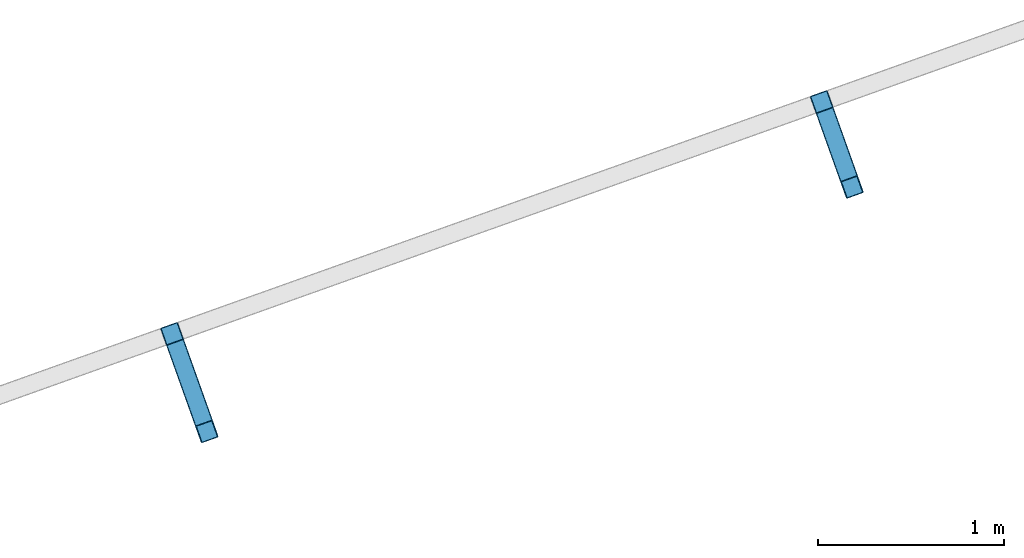
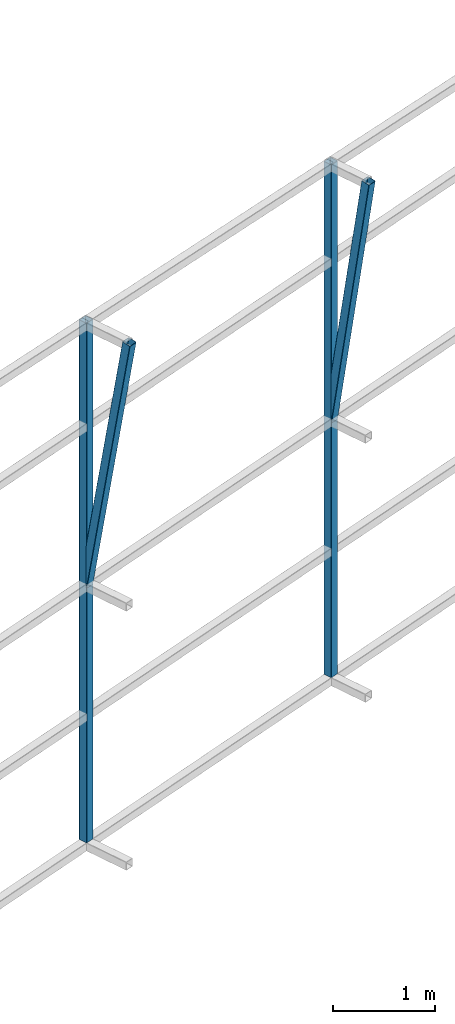
# One storey, part 137 of 215: 2 beams, 2 members, 4 elements without a shape of their own.
"""IFC2X3 building model written with IfcOpenShell, lengths in millimetres."""

from ifc_helpers import new_model, si_unit, frame, origin_with_axes, origin_2d_with_axis, place, context, subcontext, project, spatial, hollow_rectangle, extrude, material, type_object, element, aggregate, save


model = new_model("IFC2X3")

# Units and contexts
model_context = context("Model", 3, precision=1e-05, world=origin_with_axes())
body_context = subcontext(model_context, "Body", "Model", "MODEL_VIEW")
ifc_project = project(units=[si_unit("LENGTHUNIT", "METRE", prefix="MILLI"), si_unit("AREAUNIT", "SQUARE_METRE"), si_unit("VOLUMEUNIT", "CUBIC_METRE"), si_unit("MASSUNIT", "GRAM", prefix="KILO"), si_unit("TIMEUNIT", "SECOND"), si_unit("PLANEANGLEUNIT", "RADIAN"), si_unit("SOLIDANGLEUNIT", "STERADIAN"), si_unit("THERMODYNAMICTEMPERATUREUNIT", "DEGREE_CELSIUS"), si_unit("LUMINOUSINTENSITYUNIT", "LUMEN")], contexts=[model_context])

# Site, building, storey
site_placement = place(None, origin_with_axes())
site = spatial("IfcSite", under=ifc_project, at=site_placement, CompositionType="ELEMENT")
building_placement = place(site_placement, origin_with_axes())
building = spatial("IfcBuilding", under=site, at=building_placement, Name="Undefined", CompositionType="ELEMENT")
storey_placement = place(building_placement, origin_with_axes())
storey = spatial("IfcBuildingStorey", under=building, at=storey_placement, Name="Undefined", CompositionType="ELEMENT", Elevation=0.0)

# Assembly, beam
assembly_1_placement = place(storey_placement, origin_with_axes())
assembly_1 = element("IfcElementAssembly", 1, at=assembly_1_placement, inside=storey, Name="Steel Assembly", AssemblyPlace="NOTDEFINED", PredefinedType="RIGID_FRAME")
ifc_material = material(Name="STEEL/S275JR")
beam_type = type_object("IfcBeamType", PredefinedType="NOTDEFINED")
beam_1_placement = place(assembly_1_placement, frame((134709.769135225, 86663.4326501509, 6356.52129633604), z_axis=(0.941802170974673, 0.33616762299096, 0.0), x_axis=(0.0, 0.0, -1.0)))
beam_1 = element("IfcBeam", 2, at=beam_1_placement, type_object=beam_type, material=ifc_material, Name="LISSE", context=body_context, shape_type="SweptSolid", body=[
    extrude(hollow_rectangle(XDim=100.0, YDim=100.0, WallThickness=4.0, InnerFilletRadius=4.0, OuterFilletRadius=8.0, at=origin_2d_with_axis()), frame((6156.51940254423, -1.97336447760406e-20, -6.51846846795665e-19), z_axis=(-1.0, 0.0, 0.0), x_axis=(-6.93889390390723e-18, -1.0, -3.46944695195361e-18)), (0.0, 0.0, 1.0), 6156.5),
])
aggregate(assembly_1, [beam_1])

assembly_2_placement = place(storey_placement, origin_with_axes())
assembly_2 = element("IfcElementAssembly", 3, at=assembly_2_placement, inside=storey, Name="Steel Assembly", AssemblyPlace="NOTDEFINED", PredefinedType="RIGID_FRAME")
beam_2_placement = place(assembly_2_placement, frame((131209.006965009, 85413.8897043371, 6438.32400194992), z_axis=(0.941802170974673, 0.33616762299096, 0.0), x_axis=(0.0, 0.0, -1.0)))
beam_2 = element("IfcBeam", 4, at=beam_2_placement, type_object=beam_type, material=ifc_material, Name="LISSE", context=body_context, shape_type="SweptSolid", body=[
    extrude(hollow_rectangle(XDim=100.0, YDim=100.0, WallThickness=4.0, InnerFilletRadius=4.0, OuterFilletRadius=8.0, at=origin_2d_with_axis()), frame((6238.32211577862, 7.2759572549838e-12, 0.0), z_axis=(-1.0, 0.0, 0.0), x_axis=(-6.93889390390723e-18, -1.0, -3.46944695195361e-18)), (0.0, 0.0, 1.0), 6238.3),
])
aggregate(assembly_2, [beam_2])

# Assembly, member
assembly_3_placement = place(storey_placement, origin_with_axes())
assembly_3 = element("IfcElementAssembly", 5, at=assembly_3_placement, inside=storey, Name="Steel Assembly", AssemblyPlace="NOTDEFINED", PredefinedType="RIGID_FRAME")
member_type = type_object("IfcMemberType", PredefinedType="NOTDEFINED")
member_1_placement = place(assembly_3_placement, frame((134873.588336122, 86204.4827695483, 6340.43850653091), z_axis=(0.941802170974673, 0.33616762299096, 0.0), x_axis=(-0.0525260650218349, 0.147158815061178, -0.987717214410639)))
member_1 = element("IfcMember", 6, at=member_1_placement, type_object=member_type, material=ifc_material, Name="LISSE", context=body_context, shape_type="SweptSolid", body=[
    extrude(hollow_rectangle(XDim=100.0, YDim=100.0, WallThickness=4.0, InnerFilletRadius=4.0, OuterFilletRadius=8.0, at=origin_2d_with_axis()), frame((3118.74750363492, -7.27595761418343e-12, 4.03483887635062e-15), z_axis=(-1.0, 0.0, 0.0), x_axis=(-6.93889390390723e-18, -1.0, -3.46944695195361e-18)), (0.0, 0.0, 1.0), 3118.7),
])
aggregate(assembly_3, [member_1])

assembly_4_placement = place(storey_placement, origin_with_axes())
assembly_4 = element("IfcElementAssembly", 7, at=assembly_4_placement, inside=storey, Name="Steel Assembly", AssemblyPlace="NOTDEFINED", PredefinedType="RIGID_FRAME")
member_2_placement = place(assembly_4_placement, frame((131397.079442629, 84886.9910149951, 6422.28156963483), z_axis=(0.941802159599809, 0.336167654857156, 9.87999999359464e-07), x_axis=(-0.0585630390117247, 0.164072209032848, -0.984708424197129)))
member_2 = element("IfcMember", 8, at=member_2_placement, type_object=member_type, material=ifc_material, Name="LISSE", context=body_context, shape_type="SweptSolid", body=[
    extrude(hollow_rectangle(XDim=100.0, YDim=100.0, WallThickness=4.0, InnerFilletRadius=4.0, OuterFilletRadius=8.0, at=origin_2d_with_axis()), frame((3211.39088694017, 0.0, 3.94714730266761e-14), z_axis=(-1.0, 0.0, 0.0), x_axis=(-6.93889390390723e-18, -1.0, -3.46944695195361e-18)), (0.0, 0.0, 1.0), 3211.4),
])
aggregate(assembly_4, [member_2])

save(model, "model.ifc")
